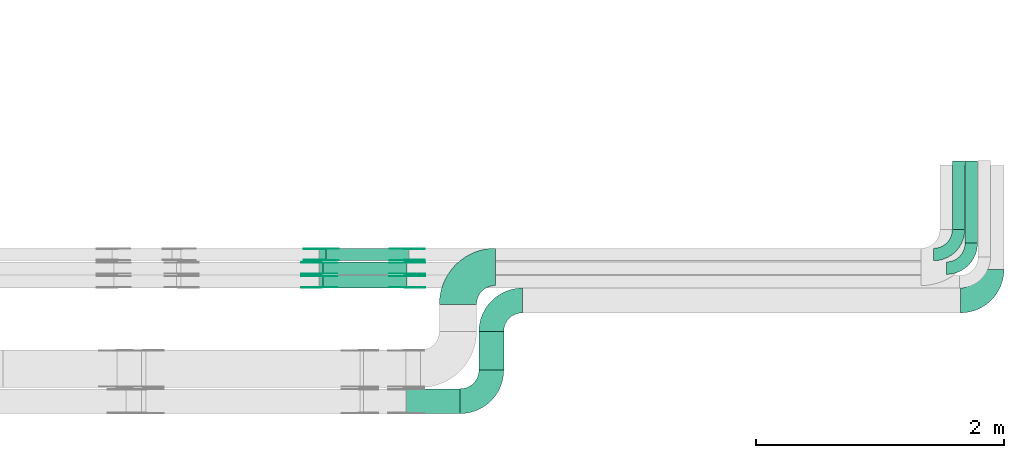
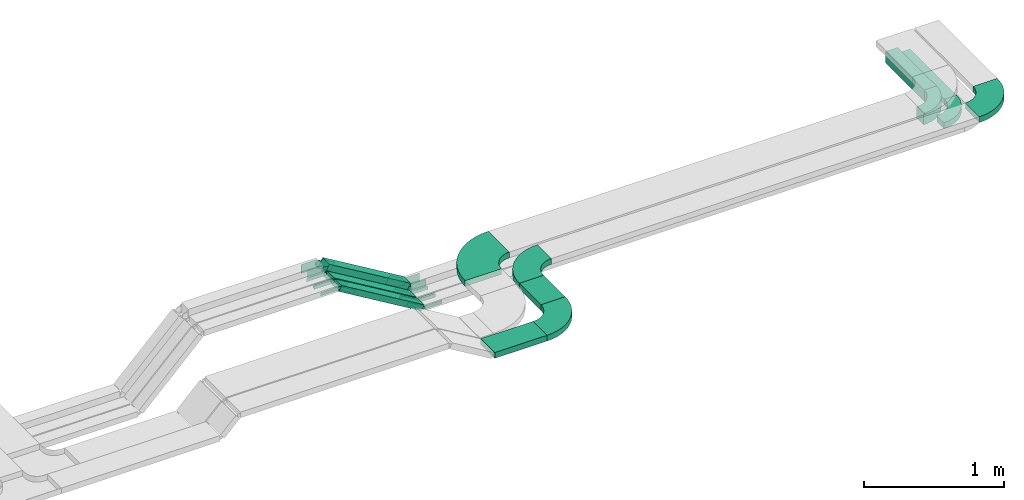
# One storey, part 17 of 19: 30 flow fittings, 7 flow segments.
"""IFC2X3 building model written with IfcOpenShell, lengths in millimetres."""

from ifc_helpers import new_model, entity, si_unit, converted_unit, derived_unit, direction, frame, frame_2d, origin, origin_2d_with_axis, place, context, subcontext, project, spatial, polyline, circle_curve, parameter, trimmed, segment, composite_curve, rectangle, outline, extrude, source, transform, mapped, material, type_object, type_shapes, element, save


model = new_model("IFC2X3")

# Units and contexts
model_context = context("Model", 3, precision=0.01, world=origin(), true_north=direction((6.12303176911189e-17, 1.0)))
body_context = subcontext(model_context, "Body", "Model", "MODEL_VIEW")
ifc_project = project(units=[si_unit("LENGTHUNIT", "METRE", prefix="MILLI"), si_unit("AREAUNIT", "SQUARE_METRE"), si_unit("VOLUMEUNIT", "CUBIC_METRE"), converted_unit("PLANEANGLEUNIT", "DEGREE", entity("IfcRatioMeasure", 0.0174532925199433), si_unit("PLANEANGLEUNIT", "RADIAN"), dimensions=[0, 0, 0, 0, 0, 0, 0]), si_unit("MASSUNIT", "GRAM", prefix="KILO"), derived_unit("MASSDENSITYUNIT", [(si_unit("MASSUNIT", "GRAM", prefix="KILO"), 1), (si_unit("LENGTHUNIT", "METRE"), -3)]), derived_unit("MOMENTOFINERTIAUNIT", [(si_unit("LENGTHUNIT", "METRE"), 4)]), si_unit("TIMEUNIT", "SECOND"), si_unit("FREQUENCYUNIT", "HERTZ"), si_unit("THERMODYNAMICTEMPERATUREUNIT", "DEGREE_CELSIUS"), derived_unit("THERMALTRANSMITTANCEUNIT", [(si_unit("MASSUNIT", "GRAM", prefix="KILO"), 1), (si_unit("THERMODYNAMICTEMPERATUREUNIT", "KELVIN"), -1), (si_unit("TIMEUNIT", "SECOND"), -3)]), derived_unit("VOLUMETRICFLOWRATEUNIT", [(si_unit("LENGTHUNIT", "METRE"), 3), (si_unit("TIMEUNIT", "SECOND"), -1)]), derived_unit("MASSFLOWRATEUNIT", [(si_unit("MASSUNIT", "GRAM", prefix="KILO"), 1), (si_unit("TIMEUNIT", "SECOND"), -1)]), derived_unit("ROTATIONALFREQUENCYUNIT", [(si_unit("TIMEUNIT", "SECOND"), -1)]), si_unit("ELECTRICCURRENTUNIT", "AMPERE"), si_unit("ELECTRICVOLTAGEUNIT", "VOLT"), si_unit("POWERUNIT", "WATT"), si_unit("FORCEUNIT", "NEWTON", prefix="KILO"), si_unit("ILLUMINANCEUNIT", "LUX"), si_unit("LUMINOUSFLUXUNIT", "LUMEN"), si_unit("LUMINOUSINTENSITYUNIT", "CANDELA"), derived_unit("USERDEFINED", [(si_unit("MASSUNIT", "GRAM", prefix="KILO"), -1), (si_unit("LENGTHUNIT", "METRE"), -2), (si_unit("TIMEUNIT", "SECOND"), 3), (si_unit("LUMINOUSFLUXUNIT", "LUMEN"), 1)]), derived_unit("LINEARVELOCITYUNIT", [(si_unit("LENGTHUNIT", "METRE"), 1), (si_unit("TIMEUNIT", "SECOND"), -1)]), si_unit("PRESSUREUNIT", "PASCAL"), derived_unit("USERDEFINED", [(si_unit("LENGTHUNIT", "METRE"), -2), (si_unit("MASSUNIT", "GRAM", prefix="KILO"), 1), (si_unit("TIMEUNIT", "SECOND"), -2)]), derived_unit("LINEARFORCEUNIT", [(si_unit("MASSUNIT", "GRAM", prefix="KILO"), 1), (si_unit("LENGTHUNIT", "METRE"), 1), (si_unit("TIMEUNIT", "SECOND"), -2), (si_unit("LENGTHUNIT", "METRE"), -1)]), derived_unit("PLANARFORCEUNIT", [(si_unit("MASSUNIT", "GRAM", prefix="KILO"), 1), (si_unit("LENGTHUNIT", "METRE"), 1), (si_unit("TIMEUNIT", "SECOND"), -2), (si_unit("LENGTHUNIT", "METRE"), -2)])], contexts=[model_context])

# Site, building, storey
site_placement = place(None, frame((0.0, -0.00077364408347762, 0.0)))
site = spatial("IfcSite", under=ifc_project, at=site_placement, CompositionType="ELEMENT")
building_placement = place(site_placement, origin())
building = spatial("IfcBuilding", under=site, at=building_placement, CompositionType="ELEMENT")
storey_placement = place(building_placement, frame((0.0, 0.0, 12000.0)))
storey = spatial("IfcBuildingStorey", under=building, at=storey_placement, CompositionType="ELEMENT", Elevation=12000.0)

# Flow segments
cable_carrier_segment_type = type_object("IfcCableCarrierSegmentType", PredefinedType="CABLETRAYSEGMENT")
flow_segment_1_placement = place(storey_placement, frame((68387.4951164855, 10095.98776832, 2600.0)))
element("IfcFlowSegment", 1, at=flow_segment_1_placement, inside=storey, type_object=cable_carrier_segment_type, context=body_context, shape_type="SweptSolid", body=[
    extrude(rectangle(XDim=554.131964439549, YDim=99.9999999999946, at=frame_2d((0.0, -4.33075797445781e-12), x_axis=(1.0, 0.0))), frame((50.0, 277.065982219776, 0.0), z_axis=(0.0, 0.0, 1.0), x_axis=(0.0, -1.0, 0.0)), (0.0, 0.0, 1.0), 99.9999999999989),
])
flow_segment_2_placement = place(storey_placement, frame((63291.748453239, 9844.98776832002, 2615.26358807534)))
element("IfcFlowSegment", 2, at=flow_segment_2_placement, inside=storey, type_object=cable_carrier_segment_type, context=body_context, shape_type="SweptSolid", body=[
    extrude(rectangle(XDim=100.000000000001, YDim=99.9999999999989, at=origin_2d_with_axis()), frame((25.6682034284367, 50.0, 441.564277698729), z_axis=(0.85817092301159, 0.0, -0.513364068568727), x_axis=(0.513364068568727, 0.0, 0.85817092301159)), (0.0, 0.0, 1.0), 776.555579083693),
])
flow_segment_3_placement = place(storey_placement, frame((63291.7484532389, 9734.98776832002, 2608.1721342259)))
element("IfcFlowSegment", 3, at=flow_segment_3_placement, inside=storey, type_object=cable_carrier_segment_type, context=body_context, shape_type="SweptSolid", body=[
    extrude(rectangle(XDim=49.9999999999925, YDim=99.9999999999989, at=origin_2d_with_axis()), frame((12.834101714214, 50.0, 427.201458472924), z_axis=(0.858170923011643, 0.0, -0.513364068568637), x_axis=(0.513364068568637, 0.0, 0.858170923011643)), (0.0, 0.0, 1.0), 790.369272490984),
])
flow_segment_4_placement = place(storey_placement, frame((68490.2510631603, 9985.98776832002, 2600.0)))
element("IfcFlowSegment", 4, at=flow_segment_4_placement, inside=storey, type_object=cable_carrier_segment_type, context=body_context, shape_type="SweptSolid", body=[
    extrude(rectangle(XDim=664.131964439559, YDim=99.9999999999946, at=frame_2d((0.0, 4.33075797445781e-12), x_axis=(1.0, 0.0))), frame((50.0, 332.06598221978, 0.0), z_axis=(0.0, 0.0, 1.0), x_axis=(0.0, 1.0, 0.0)), (0.0, 0.0, 1.0), 50.0000000000038),
])
flow_segment_5_placement = place(storey_placement, frame((63291.7484532388, 9624.98776832, 2608.1721342259)))
element("IfcFlowSegment", 5, at=flow_segment_5_placement, inside=storey, type_object=cable_carrier_segment_type, context=body_context, shape_type="SweptSolid", body=[
    extrude(rectangle(XDim=49.9999999999962, YDim=99.9999999999989, at=frame_2d((1.85629289717326e-12, 0.0), x_axis=(1.0, 0.0))), frame((12.8341017142054, 50.0, 427.201458472919), z_axis=(0.858170923011666, 0.0, -0.513364068568599), x_axis=(0.513364068568599, 0.0, 0.858170923011666)), (0.0, 0.0, 1.0), 790.369272491001),
])
flow_segment_6_placement = place(storey_placement, frame((63992.0231638909, 8613.81713290521, 2800.0)))
element("IfcFlowSegment", 6, at=flow_segment_6_placement, inside=storey, type_object=cable_carrier_segment_type, context=body_context, shape_type="SweptSolid", body=[
    extrude(rectangle(XDim=432.202301983457, YDim=200.0, at=frame_2d((-4.33431068813661e-12, 0.0), x_axis=(1.0, 0.0))), frame((216.101150991733, 100.0, 0.0)), (0.0, 0.0, 1.0), 50.0000000000016),
])
flow_segment_7_placement = place(storey_placement, frame((64575.2254658744, 8964.81713290521, 2800.0)))
element("IfcFlowSegment", 7, at=flow_segment_7_placement, inside=storey, type_object=cable_carrier_segment_type, context=body_context, shape_type="SweptSolid", body=[
    extrude(rectangle(XDim=309.170635414788, YDim=200.000000000007, at=frame_2d((1.08002495835535e-12, 0.0), x_axis=(1.0, 0.0))), frame((100.0, 154.585317707401, 0.0), z_axis=(0.0, 0.0, 1.0), x_axis=(0.0, -1.0, 0.0)), (0.0, 0.0, 1.0), 50.0000000000016),
])

# Flow fittings
ifc_material_1 = material(Name="G")
cable_carrier_fitting_type_1 = type_object("IfcCableCarrierFittingType", PredefinedType="NOTDEFINED", material=ifc_material_1)
shared_shape_1 = source(origin(), body_context, "Body", "SweptSolid", [
    extrude(outline(composite_curve([segment(trimmed(circle_curve(frame_2d((-44.5901162790698, 0.0), x_axis=(1.0, 0.0)), 12.5), [parameter(90.0000000000007)], [parameter(270.0)], True, "PARAMETER"), True, "CONTINUOUS"), segment(polyline([(-44.5901162790697, -12.5), (-33.0901162790698, -12.5)]), True, "CONTINUOUS"), segment(polyline([(-33.0901162790698, -12.5), (-31.2296511627907, -14.5)]), True, "CONTINUOUS"), segment(polyline([(-31.2296511627907, -14.5), (108.90988372093, -14.5)]), True, "CONTINUOUS"), segment(polyline([(108.90988372093, -14.5), (108.90988372093, 14.5)]), True, "CONTINUOUS"), segment(polyline([(108.90988372093, 14.5), (-31.2296511627907, 14.5)]), True, "CONTINUOUS"), segment(polyline([(-31.2296511627907, 14.5), (-33.0901162790698, 12.5)]), True, "CONTINUOUS"), segment(polyline([(-33.0901162790698, 12.5), (-44.5901162790699, 12.5)]), True, "CONTINUOUS")], self_intersect=False)), frame((44.5901162790698, 0.0, 0.0), z_axis=(0.0, 0.0, -1.0), x_axis=(1.0, 0.0, 0.0)), (0.0, 0.0, -1.0), 2.0),
])
type_shapes(cable_carrier_fitting_type_1, [shared_shape_1])
for number, where, z_axis, x_axis in (
    (8, (63296.8487682178, 9739.52776830986, 3040.0), (0.0, -1.0, 0.0), (-1.0, 0.0, 0.0)),
    (9, (63990.588269782, 9739.52776830986, 2625.0), (0.0, -1.0, 0.0), (1.0, 0.0, 0.0)),
    (10, (63990.588269782, 9629.52776830984, 2625.0), (0.0, -1.0, 0.0), (1.0, 0.0, 0.0)),
    (11, (63296.8487682177, 9629.52776830984, 3040.0), (0.0, -1.0, 0.0), (-1.0, 0.0, 0.0)),
):
    element("IfcFlowFitting", number, at=place(storey_placement, frame(where, z_axis=z_axis, x_axis=x_axis)), inside=storey, type_object=cable_carrier_fitting_type_1, material=ifc_material_1, context=body_context, shape_type="MappedRepresentation", body=[
        mapped(shared_shape_1, transform((0.0, 0.0, 0.0), scale=1.0)),
    ])
cable_carrier_fitting_type_2 = type_object("IfcCableCarrierFittingType", PredefinedType="NOTDEFINED", material=ifc_material_1)
shared_shape_2 = source(origin(), body_context, "Body", "SweptSolid", [
    extrude(outline(composite_curve([segment(trimmed(circle_curve(frame_2d((-44.5901162790697, 0.0), x_axis=(1.0, 0.0)), 12.5), [parameter(90.0000000000007)], [parameter(270.0)], True, "PARAMETER"), True, "CONTINUOUS"), segment(polyline([(-44.5901162790697, -12.5), (-33.0901162790697, -12.5)]), True, "CONTINUOUS"), segment(polyline([(-33.0901162790697, -12.5), (-31.2296511627907, -14.5)]), True, "CONTINUOUS"), segment(polyline([(-31.2296511627907, -14.5), (108.90988372093, -14.5)]), True, "CONTINUOUS"), segment(polyline([(108.90988372093, -14.5), (108.90988372093, 14.5)]), True, "CONTINUOUS"), segment(polyline([(108.90988372093, 14.5), (-31.2296511627907, 14.5)]), True, "CONTINUOUS"), segment(polyline([(-31.2296511627907, 14.5), (-33.0901162790698, 12.5)]), True, "CONTINUOUS"), segment(polyline([(-33.0901162790698, 12.5), (-44.5901162790699, 12.5)]), True, "CONTINUOUS")], self_intersect=False)), frame((44.5901162790697, 0.0, 0.0)), (0.0, 0.0, 1.0), 2.0),
])
type_shapes(cable_carrier_fitting_type_2, [shared_shape_2])
for number, where, z_axis, x_axis in (
    (12, (63296.8487682178, 9830.44776833018, 3040.0), (0.0, 1.0, 0.0), (-1.0, 0.0, 0.0)),
    (13, (63990.588269782, 9830.44776833018, 2625.0), (0.0, 1.0, 0.0), (1.0, 0.0, 0.0)),
    (14, (63990.588269782, 9720.44776833015, 2625.0), (0.0, 1.0, 0.0), (1.0, 0.0, 0.0)),
    (15, (63296.8487682177, 9720.44776833015, 3040.0), (0.0, 1.0, 0.0), (-1.0, 0.0, 0.0)),
):
    element("IfcFlowFitting", number, at=place(storey_placement, frame(where, z_axis=z_axis, x_axis=x_axis)), inside=storey, type_object=cable_carrier_fitting_type_2, material=ifc_material_1, context=body_context, shape_type="MappedRepresentation", body=[
        mapped(shared_shape_2, transform((0.0, 0.0, 0.0), scale=1.0)),
    ])
cable_carrier_fitting_type_3 = type_object("IfcCableCarrierFittingType", PredefinedType="NOTDEFINED", material=ifc_material_1)
shared_shape_3 = source(origin(), body_context, "Body", "SweptSolid", [
    extrude(outline(composite_curve([segment(trimmed(circle_curve(frame_2d((-44.5901162790698, 0.0), x_axis=(1.0, 0.0)), 12.5), [parameter(90.0000000000007)], [parameter(270.0)], True, "PARAMETER"), True, "CONTINUOUS"), segment(polyline([(-44.5901162790697, -12.5), (-33.0901162790698, -12.5)]), True, "CONTINUOUS"), segment(polyline([(-33.0901162790698, -12.5), (-31.2296511627907, -14.5)]), True, "CONTINUOUS"), segment(polyline([(-31.2296511627907, -14.5), (108.90988372093, -14.5)]), True, "CONTINUOUS"), segment(polyline([(108.90988372093, -14.5), (108.90988372093, 14.5)]), True, "CONTINUOUS"), segment(polyline([(108.90988372093, 14.5), (-31.2296511627907, 14.5)]), True, "CONTINUOUS"), segment(polyline([(-31.2296511627907, 14.5), (-33.0901162790698, 12.5)]), True, "CONTINUOUS"), segment(polyline([(-33.0901162790698, 12.5), (-44.5901162790699, 12.5)]), True, "CONTINUOUS")], self_intersect=False)), frame((44.5901162790698, 0.0, 0.0), z_axis=(0.0, 0.0, -1.0), x_axis=(1.0, 0.0, 0.0)), (0.0, 0.0, -1.0), 2.0),
])
type_shapes(cable_carrier_fitting_type_3, [shared_shape_3])
for number, where, z_axis, x_axis in (
    (16, (63296.8487682177, 9828.44776833018, 3040.0), (0.0, 1.0, 0.0), (0.858170923011632, 0.0, -0.513364068568655)),
    (17, (63990.588269782, 9828.44776833018, 2625.0), (0.0, 1.0, 0.0), (-0.858170923011639, 0.0, 0.513364068568644)),
    (18, (63990.588269782, 9718.44776833015, 2625.0), (0.0, 1.0, 0.0), (-0.858170923011646, 0.0, 0.513364068568632)),
    (19, (63296.8487682177, 9718.44776833015, 3040.0), (0.0, 1.0, 0.0), (0.858170923011648, 0.0, -0.51336406856863)),
):
    element("IfcFlowFitting", number, at=place(storey_placement, frame(where, z_axis=z_axis, x_axis=x_axis)), inside=storey, type_object=cable_carrier_fitting_type_3, material=ifc_material_1, context=body_context, shape_type="MappedRepresentation", body=[
        mapped(shared_shape_3, transform((0.0, 0.0, 0.0), scale=1.0)),
    ])
cable_carrier_fitting_type_4 = type_object("IfcCableCarrierFittingType", PredefinedType="NOTDEFINED", material=ifc_material_1)
shared_shape_4 = source(origin(), body_context, "Body", "SweptSolid", [
    extrude(outline(composite_curve([segment(trimmed(circle_curve(frame_2d((-44.5901162790697, 0.0), x_axis=(1.0, 0.0)), 12.5), [parameter(90.0000000000007)], [parameter(270.0)], True, "PARAMETER"), True, "CONTINUOUS"), segment(polyline([(-44.5901162790697, -12.5), (-33.0901162790697, -12.5)]), True, "CONTINUOUS"), segment(polyline([(-33.0901162790697, -12.5), (-31.2296511627907, -14.5)]), True, "CONTINUOUS"), segment(polyline([(-31.2296511627907, -14.5), (108.90988372093, -14.5)]), True, "CONTINUOUS"), segment(polyline([(108.90988372093, -14.5), (108.90988372093, 14.5)]), True, "CONTINUOUS"), segment(polyline([(108.90988372093, 14.5), (-31.2296511627907, 14.5)]), True, "CONTINUOUS"), segment(polyline([(-31.2296511627907, 14.5), (-33.0901162790698, 12.5)]), True, "CONTINUOUS"), segment(polyline([(-33.0901162790698, 12.5), (-44.5901162790699, 12.5)]), True, "CONTINUOUS")], self_intersect=False)), frame((44.5901162790697, 0.0, 0.0)), (0.0, 0.0, 1.0), 2.0),
])
type_shapes(cable_carrier_fitting_type_4, [shared_shape_4])
for number, where, z_axis, x_axis in (
    (20, (63296.8487682177, 9741.52776830987, 3040.0), (0.0, -1.0, 0.0), (0.858170923011632, 0.0, -0.513364068568655)),
    (21, (63990.588269782, 9741.52776830987, 2625.0), (0.0, -1.0, 0.0), (-0.858170923011639, 0.0, 0.513364068568644)),
    (22, (63990.588269782, 9631.52776830984, 2625.0), (0.0, -1.0, 0.0), (-0.858170923011646, 0.0, 0.513364068568632)),
    (23, (63296.8487682177, 9631.52776830984, 3040.0), (0.0, -1.0, 0.0), (0.858170923011648, 0.0, -0.51336406856863)),
):
    element("IfcFlowFitting", number, at=place(storey_placement, frame(where, z_axis=z_axis, x_axis=x_axis)), inside=storey, type_object=cable_carrier_fitting_type_4, material=ifc_material_1, context=body_context, shape_type="MappedRepresentation", body=[
        mapped(shared_shape_4, transform((0.0, 0.0, 0.0), scale=1.0)),
    ])
ifc_material_2 = material()
cable_carrier_fitting_type_5 = type_object("IfcCableCarrierFittingType", Name="470_DKC_S5_Variable Angle Elbow 0-45:-", PredefinedType="NOTDEFINED", material=ifc_material_2)
shared_shape_5 = source(origin(), body_context, "Body", "SweptSolid", [
    extrude(outline(composite_curve([segment(polyline([(-150.749999999996, -300.250000000003), (-149.749999999994, -300.250000000003)]), True, "CONTINUOUS"), segment(trimmed(circle_curve(frame_2d((-149.750000000002, 149.749999999997), x_axis=(0.0, -1.0)), 450.0), [parameter(0.0)], [parameter(90.0000000000001)], True, "PARAMETER"), True, "CONTINUOUS"), segment(polyline([(300.249999999997, 149.750000000005), (300.249999999997, 150.750000000004)]), True, "CONTINUOUS"), segment(polyline([(300.249999999997, 150.750000000003), (0.249999999997449, 150.750000000002)]), True, "CONTINUOUS"), segment(polyline([(0.249999999997449, 150.750000000002), (0.249999999997438, 149.75)]), True, "CONTINUOUS"), segment(trimmed(circle_curve(frame_2d((-149.750000000002, 149.749999999997), x_axis=(0.0, -1.0)), 150.0), [parameter(0.0)], [parameter(90.0000000000001)], True, "PARAMETER"), False, "CONTINUOUS"), segment(polyline([(-149.749999999999, -0.250000000002818), (-150.750000000001, -0.250000000002835)]), True, "CONTINUOUS"), segment(polyline([(-150.750000000001, -0.250000000002835), (-150.749999999996, -300.250000000003)]), True, "CONTINUOUS")], self_intersect=False)), frame((-150.249999999991, 150.249999999992, -25.0)), (0.0, 0.0, 1.0), 49.9999999999974),
])
type_shapes(cable_carrier_fitting_type_5, [shared_shape_5])
flow_fitting_1_placement = place(storey_placement, frame((64406.4356901398, 9794.98776832002, 2825.0), z_axis=(0.0, 0.0, 1.0), x_axis=(-1.0, 0.0, 0.0)))
element("IfcFlowFitting", 24, at=flow_fitting_1_placement, inside=storey, type_object=cable_carrier_fitting_type_5, material=ifc_material_2, Name="470_DKC_S5_Variable Angle Elbow 0-45:-", ObjectType="470_DKC_S5_Variable Angle Elbow 0-45:-", context=body_context, shape_type="MappedRepresentation", body=[
    mapped(shared_shape_5, transform((0.0, 0.0, 0.0), scale=1.0)),
])
cable_carrier_fitting_type_6 = type_object("IfcCableCarrierFittingType", Name="470_DKC_S5_Variable Angle Elbow 0-45:-", PredefinedType="NOTDEFINED", material=ifc_material_2)
shared_shape_6 = source(origin(), body_context, "Body", "SweptSolid", [
    extrude(outline(composite_curve([segment(polyline([(-125.750000000004, -225.249999999998), (-124.750000000003, -225.249999999998)]), True, "CONTINUOUS"), segment(trimmed(circle_curve(frame_2d((-124.749999999998, 124.750000000002), x_axis=(0.0, -1.0)), 350.0), [parameter(0.0)], [parameter(90.0000000000001)], True, "PARAMETER"), True, "CONTINUOUS"), segment(polyline([(225.250000000002, 124.749999999996), (225.250000000002, 125.749999999995)]), True, "CONTINUOUS"), segment(polyline([(225.250000000002, 125.749999999995), (25.2500000000021, 125.750000000001)]), True, "CONTINUOUS"), segment(polyline([(25.2500000000021, 125.750000000001), (25.2500000000021, 124.749999999999)]), True, "CONTINUOUS"), segment(trimmed(circle_curve(frame_2d((-124.749999999998, 124.750000000002), x_axis=(0.0, -1.0)), 150.0), [parameter(0.0)], [parameter(90.0000000000001)], True, "PARAMETER"), False, "CONTINUOUS"), segment(polyline([(-124.75, -25.2499999999982), (-125.750000000001, -25.2499999999981)]), True, "CONTINUOUS"), segment(polyline([(-125.750000000001, -25.2499999999981), (-125.750000000004, -225.249999999998)]), True, "CONTINUOUS")], self_intersect=False)), frame((-125.249999999991, 125.249999999992, -25.0)), (0.0, 0.0, 1.0), 50.000000000001),
])
type_shapes(cable_carrier_fitting_type_6, [shared_shape_6])
flow_fitting_2_placement = place(storey_placement, frame((68703.9467817498, 9524.98776832001, 2825.0)))
element("IfcFlowFitting", 25, at=flow_fitting_2_placement, inside=storey, type_object=cable_carrier_fitting_type_6, material=ifc_material_2, Name="470_DKC_S5_Variable Angle Elbow 0-45:-", ObjectType="470_DKC_S5_Variable Angle Elbow 0-45:-", context=body_context, shape_type="MappedRepresentation", body=[
    mapped(shared_shape_6, transform((0.0, 0.0, 0.0), scale=1.0)),
])
flow_fitting_3_placement = place(storey_placement, frame((64675.2254658744, 9524.98776831998, 2825.0), z_axis=(0.0, 0.0, 1.0), x_axis=(-1.0, 0.0, 0.0)))
element("IfcFlowFitting", 26, at=flow_fitting_3_placement, inside=storey, type_object=cable_carrier_fitting_type_6, material=ifc_material_2, Name="470_DKC_S5_Variable Angle Elbow 0-45:-", ObjectType="470_DKC_S5_Variable Angle Elbow 0-45:-", context=body_context, shape_type="MappedRepresentation", body=[
    mapped(shared_shape_6, transform((0.0, 0.0, 0.0), scale=1.0)),
])
flow_fitting_4_placement = place(storey_placement, frame((64675.2254658744, 8713.81713290523, 2825.0)))
element("IfcFlowFitting", 27, at=flow_fitting_4_placement, inside=storey, type_object=cable_carrier_fitting_type_6, material=ifc_material_2, Name="470_DKC_S5_Variable Angle Elbow 0-45:-", ObjectType="470_DKC_S5_Variable Angle Elbow 0-45:-", context=body_context, shape_type="MappedRepresentation", body=[
    mapped(shared_shape_6, transform((0.0, 0.0, 0.0), scale=1.0)),
])
cable_carrier_fitting_type_7 = type_object("IfcCableCarrierFittingType", PredefinedType="NOTDEFINED", material=ifc_material_1)
shared_shape_7 = source(origin(), body_context, "Body", "SweptSolid", [
    extrude(outline(composite_curve([segment(trimmed(circle_curve(frame_2d((-41.4651162790697, 0.0), x_axis=(1.0, 0.0)), 25.0), [parameter(90.0000000000007)], [parameter(270.0)], True, "PARAMETER"), True, "CONTINUOUS"), segment(polyline([(-41.4651162790697, -25.0), (-29.9651162790697, -25.0)]), True, "CONTINUOUS"), segment(polyline([(-29.9651162790697, -25.0), (-28.1046511627907, -38.5)]), True, "CONTINUOUS"), segment(polyline([(-28.1046511627907, -38.5), (99.5348837209303, -38.5)]), True, "CONTINUOUS"), segment(polyline([(99.5348837209303, -38.5), (99.5348837209303, 38.5)]), True, "CONTINUOUS"), segment(polyline([(99.5348837209303, 38.5), (-28.1046511627907, 38.5)]), True, "CONTINUOUS"), segment(polyline([(-28.1046511627907, 38.5), (-29.9651162790697, 25.0)]), True, "CONTINUOUS"), segment(polyline([(-29.9651162790697, 25.0), (-41.46511627907, 25.0)]), True, "CONTINUOUS")], self_intersect=False)), frame((41.4651162790697, 0.0, 0.0), z_axis=(0.0, 0.0, -1.0), x_axis=(1.0, 0.0, 0.0)), (0.0, 0.0, -1.0), 2.0),
])
type_shapes(cable_carrier_fitting_type_7, [shared_shape_7])
for number, where, z_axis, x_axis in (
    (28, (63997.4951164855, 9940.44776833018, 2650.0), (0.0, 1.0, 0.0), (-0.858170923011602, 0.0, 0.513364068568707)),
    (29, (63303.7556149213, 9940.44776833018, 3065.0), (0.0, 1.0, 0.0), (0.858170923011602, 0.0, -0.513364068568707)),
):
    element("IfcFlowFitting", number, at=place(storey_placement, frame(where, z_axis=z_axis, x_axis=x_axis)), inside=storey, type_object=cable_carrier_fitting_type_7, material=ifc_material_1, context=body_context, shape_type="MappedRepresentation", body=[
        mapped(shared_shape_7, transform((0.0, 0.0, 0.0), scale=1.0)),
    ])
cable_carrier_fitting_type_8 = type_object("IfcCableCarrierFittingType", PredefinedType="NOTDEFINED", material=ifc_material_1)
shared_shape_8 = source(origin(), body_context, "Body", "SweptSolid", [
    extrude(outline(composite_curve([segment(trimmed(circle_curve(frame_2d((-41.4651162790697, 0.0), x_axis=(1.0, 0.0)), 25.0), [parameter(90.0000000000007)], [parameter(270.0)], True, "PARAMETER"), True, "CONTINUOUS"), segment(polyline([(-41.4651162790697, -25.0), (-29.9651162790697, -25.0)]), True, "CONTINUOUS"), segment(polyline([(-29.9651162790697, -25.0), (-28.1046511627907, -38.5)]), True, "CONTINUOUS"), segment(polyline([(-28.1046511627907, -38.5), (99.5348837209303, -38.5)]), True, "CONTINUOUS"), segment(polyline([(99.5348837209303, -38.5), (99.5348837209303, 38.5)]), True, "CONTINUOUS"), segment(polyline([(99.5348837209303, 38.5), (-28.1046511627907, 38.5)]), True, "CONTINUOUS"), segment(polyline([(-28.1046511627907, 38.5), (-29.9651162790697, 25.0)]), True, "CONTINUOUS"), segment(polyline([(-29.9651162790697, 25.0), (-41.46511627907, 25.0)]), True, "CONTINUOUS")], self_intersect=False)), frame((41.4651162790697, 0.0, 0.0)), (0.0, 0.0, 1.0), 2.0),
])
type_shapes(cable_carrier_fitting_type_8, [shared_shape_8])
for number, where, z_axis, x_axis in (
    (30, (63997.4951164855, 9849.52776830986, 2650.0), (0.0, -1.0, 0.0), (-0.858170923011602, 0.0, 0.513364068568707)),
    (31, (63303.7556149213, 9849.52776830986, 3065.0), (0.0, -1.0, 0.0), (0.858170923011602, 0.0, -0.513364068568707)),
):
    element("IfcFlowFitting", number, at=place(storey_placement, frame(where, z_axis=z_axis, x_axis=x_axis)), inside=storey, type_object=cable_carrier_fitting_type_8, material=ifc_material_1, context=body_context, shape_type="MappedRepresentation", body=[
        mapped(shared_shape_8, transform((0.0, 0.0, 0.0), scale=1.0)),
    ])
cable_carrier_fitting_type_9 = type_object("IfcCableCarrierFittingType", PredefinedType="NOTDEFINED", material=ifc_material_1)
shared_shape_9 = source(origin(), body_context, "Body", "SweptSolid", [
    extrude(outline(composite_curve([segment(trimmed(circle_curve(frame_2d((-41.4651162790697, 0.0), x_axis=(1.0, 0.0)), 25.0), [parameter(90.0000000000007)], [parameter(270.0)], True, "PARAMETER"), True, "CONTINUOUS"), segment(polyline([(-41.4651162790697, -25.0), (-29.9651162790697, -25.0)]), True, "CONTINUOUS"), segment(polyline([(-29.9651162790697, -25.0), (-28.1046511627907, -38.5)]), True, "CONTINUOUS"), segment(polyline([(-28.1046511627907, -38.5), (99.5348837209303, -38.5)]), True, "CONTINUOUS"), segment(polyline([(99.5348837209303, -38.5), (99.5348837209303, 38.5)]), True, "CONTINUOUS"), segment(polyline([(99.5348837209303, 38.5), (-28.1046511627907, 38.5)]), True, "CONTINUOUS"), segment(polyline([(-28.1046511627907, 38.5), (-29.9651162790697, 25.0)]), True, "CONTINUOUS"), segment(polyline([(-29.9651162790697, 25.0), (-41.46511627907, 25.0)]), True, "CONTINUOUS")], self_intersect=False)), frame((41.4651162790697, 0.0, 0.0), z_axis=(0.0, 0.0, -1.0), x_axis=(1.0, 0.0, 0.0)), (0.0, 0.0, -1.0), 2.0),
])
type_shapes(cable_carrier_fitting_type_9, [shared_shape_9])
for number, where, z_axis, x_axis in (
    (32, (63997.4951164855, 9851.52776830986, 2650.0), (0.0, -1.0, 0.0), (1.0, 0.0, 0.0)),
    (33, (63303.7556149213, 9851.52776830986, 3065.0), (0.0, -1.0, 0.0), (-1.0, 0.0, 0.0)),
):
    element("IfcFlowFitting", number, at=place(storey_placement, frame(where, z_axis=z_axis, x_axis=x_axis)), inside=storey, type_object=cable_carrier_fitting_type_9, material=ifc_material_1, context=body_context, shape_type="MappedRepresentation", body=[
        mapped(shared_shape_9, transform((0.0, 0.0, 0.0), scale=1.0)),
    ])
cable_carrier_fitting_type_10 = type_object("IfcCableCarrierFittingType", PredefinedType="NOTDEFINED", material=ifc_material_1)
shared_shape_10 = source(origin(), body_context, "Body", "SweptSolid", [
    extrude(outline(composite_curve([segment(trimmed(circle_curve(frame_2d((-41.4651162790697, 0.0), x_axis=(1.0, 0.0)), 25.0), [parameter(90.0000000000007)], [parameter(270.0)], True, "PARAMETER"), True, "CONTINUOUS"), segment(polyline([(-41.4651162790697, -25.0), (-29.9651162790697, -25.0)]), True, "CONTINUOUS"), segment(polyline([(-29.9651162790697, -25.0), (-28.1046511627907, -38.5)]), True, "CONTINUOUS"), segment(polyline([(-28.1046511627907, -38.5), (99.5348837209303, -38.5)]), True, "CONTINUOUS"), segment(polyline([(99.5348837209303, -38.5), (99.5348837209303, 38.5)]), True, "CONTINUOUS"), segment(polyline([(99.5348837209303, 38.5), (-28.1046511627907, 38.5)]), True, "CONTINUOUS"), segment(polyline([(-28.1046511627907, 38.5), (-29.9651162790697, 25.0)]), True, "CONTINUOUS"), segment(polyline([(-29.9651162790697, 25.0), (-41.46511627907, 25.0)]), True, "CONTINUOUS")], self_intersect=False)), frame((41.4651162790697, 0.0, 0.0)), (0.0, 0.0, 1.0), 2.0),
])
type_shapes(cable_carrier_fitting_type_10, [shared_shape_10])
for number, where, z_axis, x_axis in (
    (34, (63997.4951164855, 9938.44776833018, 2650.0), (0.0, 1.0, 0.0), (1.0, 0.0, 0.0)),
    (35, (63303.7556149213, 9938.44776833018, 3065.0), (0.0, 1.0, 0.0), (-1.0, 0.0, 0.0)),
):
    element("IfcFlowFitting", number, at=place(storey_placement, frame(where, z_axis=z_axis, x_axis=x_axis)), inside=storey, type_object=cable_carrier_fitting_type_10, material=ifc_material_1, context=body_context, shape_type="MappedRepresentation", body=[
        mapped(shared_shape_10, transform((0.0, 0.0, 0.0), scale=1.0)),
    ])
cable_carrier_fitting_type_11 = type_object("IfcCableCarrierFittingType", Name="470_DKC_S5_Variable Angle Elbow 0-45:-", PredefinedType="NOTDEFINED", material=ifc_material_2)
shared_shape_11 = source(origin(), body_context, "Body", "SweptSolid", [
    extrude(outline(composite_curve([segment(polyline([(-100.749999999999, -150.250000000001), (-99.7499999999981, -150.250000000001)]), True, "CONTINUOUS"), segment(trimmed(circle_curve(frame_2d((-99.7500000000006, 99.7499999999987), x_axis=(0.0, -1.0)), 250.0), [parameter(0.0)], [parameter(90.0000000000001)], True, "PARAMETER"), True, "CONTINUOUS"), segment(polyline([(150.249999999999, 99.7500000000013), (150.249999999999, 100.750000000001)]), True, "CONTINUOUS"), segment(polyline([(150.249999999999, 100.750000000001), (50.2499999999992, 100.750000000001)]), True, "CONTINUOUS"), segment(polyline([(50.2499999999992, 100.750000000001), (50.2499999999992, 99.7500000000002)]), True, "CONTINUOUS"), segment(trimmed(circle_curve(frame_2d((-99.7500000000006, 99.7499999999987), x_axis=(0.0, -1.0)), 150.0), [parameter(0.0)], [parameter(90.0000000000001)], True, "PARAMETER"), False, "CONTINUOUS"), segment(polyline([(-99.7499999999989, -50.2500000000011), (-100.75, -50.2500000000011)]), True, "CONTINUOUS"), segment(polyline([(-100.75, -50.2500000000011), (-100.749999999999, -150.250000000001)]), True, "CONTINUOUS")], self_intersect=False)), frame((-100.249999999991, 100.249999999992, -50.0)), (0.0, 0.0, 1.0), 100.0),
])
type_shapes(cable_carrier_fitting_type_11, [shared_shape_11])
flow_fitting_5_placement = place(storey_placement, frame((68437.4951164855, 9894.98776832004, 2650.0)))
element("IfcFlowFitting", 36, at=flow_fitting_5_placement, inside=storey, type_object=cable_carrier_fitting_type_11, material=ifc_material_2, Name="470_DKC_S5_Variable Angle Elbow 0-45:-", ObjectType="470_DKC_S5_Variable Angle Elbow 0-45:-", context=body_context, shape_type="MappedRepresentation", body=[
    mapped(shared_shape_11, transform((0.0, 0.0, 0.0), scale=1.0)),
])
cable_carrier_fitting_type_12 = type_object("IfcCableCarrierFittingType", Name="470_DKC_S5_Variable Angle Elbow 0-45:-", PredefinedType="NOTDEFINED", material=ifc_material_2)
shared_shape_12 = source(origin(), body_context, "Body", "SweptSolid", [
    extrude(outline(composite_curve([segment(polyline([(-100.750000000001, -150.25), (-99.7499999999994, -150.25)]), True, "CONTINUOUS"), segment(trimmed(circle_curve(frame_2d((-99.7499999999997, 99.7499999999995), x_axis=(0.0, -1.0)), 250.0), [parameter(0.0)], [parameter(90.0000000000001)], True, "PARAMETER"), True, "CONTINUOUS"), segment(polyline([(150.25, 99.75), (150.25, 100.749999999999)]), True, "CONTINUOUS"), segment(polyline([(150.25, 100.749999999999), (50.25, 100.75)]), True, "CONTINUOUS"), segment(polyline([(50.25, 100.75), (50.25, 99.7499999999998)]), True, "CONTINUOUS"), segment(trimmed(circle_curve(frame_2d((-99.7499999999997, 99.7499999999995), x_axis=(0.0, -1.0)), 150.0), [parameter(0.0)], [parameter(90.0000000000001)], True, "PARAMETER"), False, "CONTINUOUS"), segment(polyline([(-99.7499999999994, -50.2500000000003), (-100.750000000001, -50.2500000000003)]), True, "CONTINUOUS"), segment(polyline([(-100.750000000001, -50.2500000000003), (-100.750000000001, -150.25)]), True, "CONTINUOUS")], self_intersect=False)), frame((-100.249999999991, 100.249999999992, -25.0)), (0.0, 0.0, 1.0), 49.9999999999997),
])
type_shapes(cable_carrier_fitting_type_12, [shared_shape_12])
flow_fitting_6_placement = place(storey_placement, frame((68540.2510631603, 9784.98776832003, 2625.0)))
element("IfcFlowFitting", 37, at=flow_fitting_6_placement, inside=storey, type_object=cable_carrier_fitting_type_12, material=ifc_material_2, Name="470_DKC_S5_Variable Angle Elbow 0-45:-", ObjectType="470_DKC_S5_Variable Angle Elbow 0-45:-", context=body_context, shape_type="MappedRepresentation", body=[
    mapped(shared_shape_12, transform((0.0, 0.0, 0.0), scale=1.0)),
])

save(model, "model.ifc")
